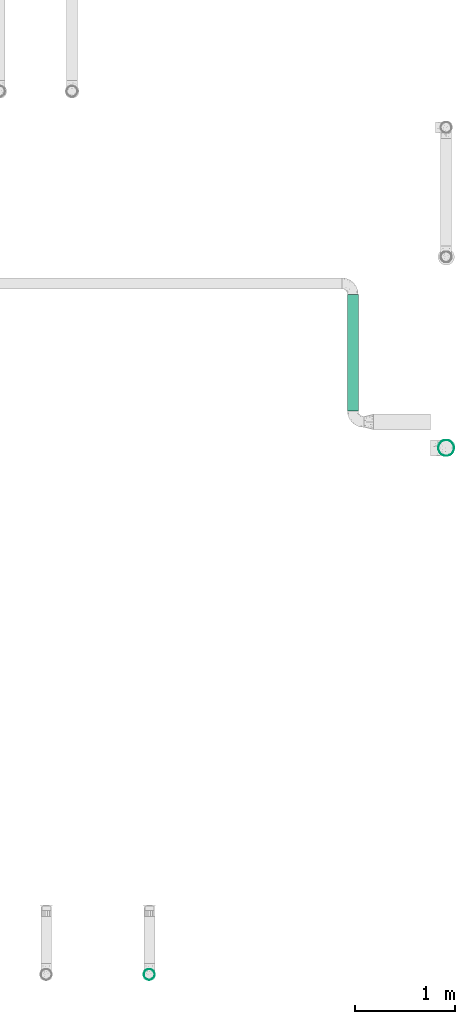
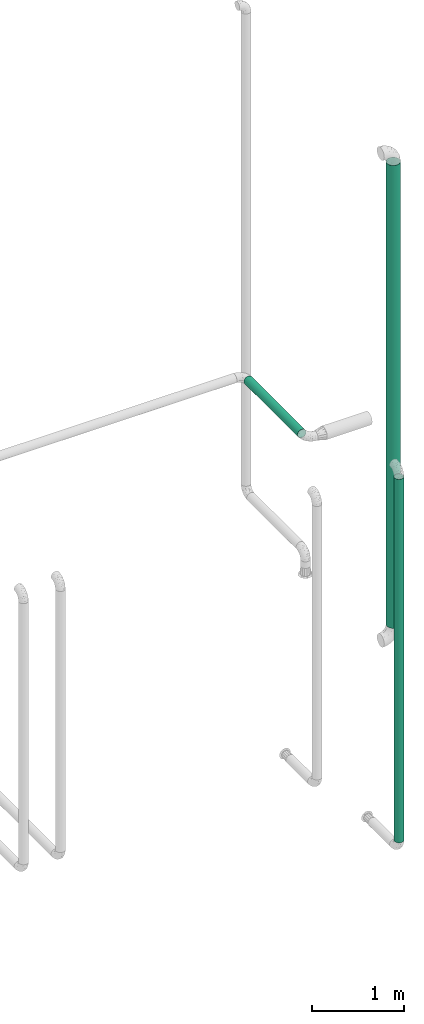
# One storey, part 11 of 115: 3 flow segments.
"""IFC2X3 building model written with IfcOpenShell, lengths in millimetres."""

from ifc_helpers import new_model, entity, si_unit, converted_unit, derived_unit, direction, frame, origin_with_axes, origin_2d_with_axis, place, context, subcontext, project, spatial, hollow_circle, extrude, source, transform, mapped, material, layer, layer_set, layer_usage, type_object, element, save


model = new_model("IFC2X3")

# Units and contexts
model_context = context("Model", 3, precision=1e-05, world=origin_with_axes(), true_north=direction((0.0, 1.0)))
body_context = subcontext(model_context, "Body", "Model", "MODEL_VIEW")
ifc_project = project(units=[si_unit("AREAUNIT", "SQUARE_METRE"), si_unit("VOLUMEUNIT", "CUBIC_METRE", prefix="DECI"), si_unit("TIMEUNIT", "SECOND"), si_unit("THERMODYNAMICTEMPERATUREUNIT", "DEGREE_CELSIUS"), si_unit("PRESSUREUNIT", "PASCAL"), si_unit("MASSUNIT", "GRAM", prefix="KILO"), si_unit("LENGTHUNIT", "METRE", prefix="MILLI"), si_unit("POWERUNIT", "WATT"), si_unit("ELECTRICCURRENTUNIT", "AMPERE"), si_unit("ELECTRICVOLTAGEUNIT", "VOLT"), derived_unit("VOLUMETRICFLOWRATEUNIT", [(si_unit("VOLUMEUNIT", "CUBIC_METRE", prefix="DECI"), 1), (si_unit("TIMEUNIT", "SECOND"), -1)]), derived_unit("LINEARVELOCITYUNIT", [(si_unit("LENGTHUNIT", "METRE"), 1), (si_unit("TIMEUNIT", "SECOND"), -1)]), derived_unit("MASSDENSITYUNIT", [(si_unit("MASSUNIT", "GRAM", prefix="KILO"), 1), (si_unit("VOLUMEUNIT", "CUBIC_METRE"), -1)]), converted_unit("PLANEANGLEUNIT", "DEGREE", entity("IfcRatioMeasure", 0.01745), si_unit("PLANEANGLEUNIT", "RADIAN"), dimensions=[0, 0, 0, 0, 0, 0, 0])], contexts=[model_context])

# Site, building, storey
site_placement = place(None, origin_with_axes())
site = spatial("IfcSite", under=ifc_project, at=site_placement, CompositionType="ELEMENT")
building_placement = place(site_placement, origin_with_axes())
building = spatial("IfcBuilding", under=site, at=building_placement, Name="mc-building", CompositionType="ELEMENT")
storey_placement = place(building_placement, frame((0.0, 0.0, 2950.0), z_axis=(0.0, 0.0, 1.0), x_axis=(1.0, 0.0, 0.0)))
storey = spatial("IfcBuildingStorey", under=building, at=storey_placement, Name="2. Korrus", CompositionType="ELEMENT", Elevation=2950.0)

# Flow segments
ifc_material = material(Name="FZ1")
ifc_layer = layer(ifc_material, 0.0)
ifc_layer_set = layer_set([ifc_layer], Name="FZ1")
ifc_layer_usage = layer_usage(ifc_layer_set, "AXIS1", "POSITIVE", 0.0)
duct_segment_type_1 = type_object("IfcDuctSegmentType", Name="Safe", PredefinedType="RIGIDSEGMENT")
shared_shape_1 = source(origin_with_axes(), body_context, "Body", "SweptSolid", [
    extrude(hollow_circle(Radius=55.0, WallThickness=2.0, at=origin_2d_with_axis()), frame((0.0, 0.0, 0.0), z_axis=(1.0, 0.0, 0.0), x_axis=(0.0, 1.0, 0.0)), (0.0, 0.0, 1.0), 4845.0),
])
flow_segment_1_placement = place(storey_placement, frame((34787.74688, -687.64676, 1210.0), z_axis=(1.0, 0.0, 0.0), x_axis=(0.0, 0.0, 1.0)))
element("IfcFlowSegment", 1, at=flow_segment_1_placement, inside=storey, type_object=duct_segment_type_1, material=ifc_layer_usage, Name="Safe", context=body_context, shape_type="MappedRepresentation", body=[
    mapped(shared_shape_1, transform((0.0, 0.0, 0.0), scale=1.0)),
])
duct_segment_type_2 = type_object("IfcDuctSegmentType", PredefinedType="RIGIDSEGMENT")
shared_shape_2 = source(origin_with_axes(), body_context, "Body", "SweptSolid", [
    extrude(hollow_circle(Radius=80.0, WallThickness=2.0, at=origin_2d_with_axis()), frame((0.0, 0.0, 0.0), z_axis=(1.0, 0.0, 0.0), x_axis=(0.0, 1.0, 0.0)), (0.0, 0.0, 1.0), 6170.0),
])
flow_segment_2_placement = place(storey_placement, frame((37769.98441, 4601.38149, 6005.0), z_axis=(-1.0, 0.0, 0.0), x_axis=(0.0, 0.0, -1.0)))
element("IfcFlowSegment", 2, at=flow_segment_2_placement, inside=storey, type_object=duct_segment_type_2, material=ifc_layer_usage, context=body_context, shape_type="MappedRepresentation", body=[
    mapped(shared_shape_2, transform((0.0, 0.0, 0.0), scale=1.0)),
])
shared_shape_3 = source(origin_with_axes(), body_context, "Body", "SweptSolid", [
    extrude(hollow_circle(Radius=55.0, WallThickness=2.0, at=origin_2d_with_axis()), frame((0.0, 0.0, 0.0), z_axis=(1.0, 0.0, 0.0), x_axis=(0.0, 1.0, 0.0)), (0.0, 0.0, 1.0), 1171.6),
])
flow_segment_3_placement = place(storey_placement, frame((36831.7547, 6144.72535, 2480.0), z_axis=(0.0, 0.0, 1.0), x_axis=(0.0, -1.0, 0.0)))
element("IfcFlowSegment", 3, at=flow_segment_3_placement, inside=storey, type_object=duct_segment_type_2, material=ifc_layer_usage, context=body_context, shape_type="MappedRepresentation", body=[
    mapped(shared_shape_3, transform((0.0, 0.0, 0.0), scale=1.0)),
])

save(model, "model.ifc")
